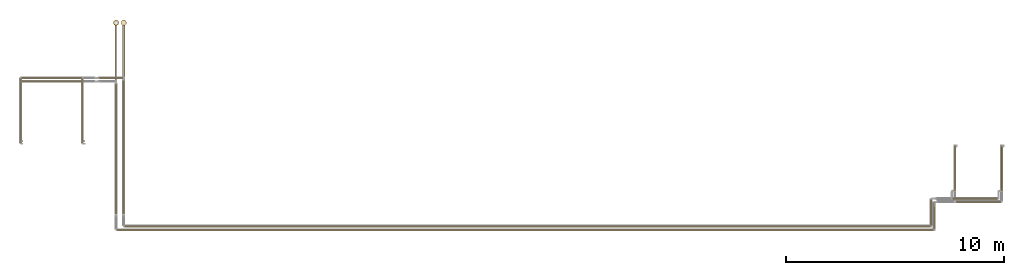
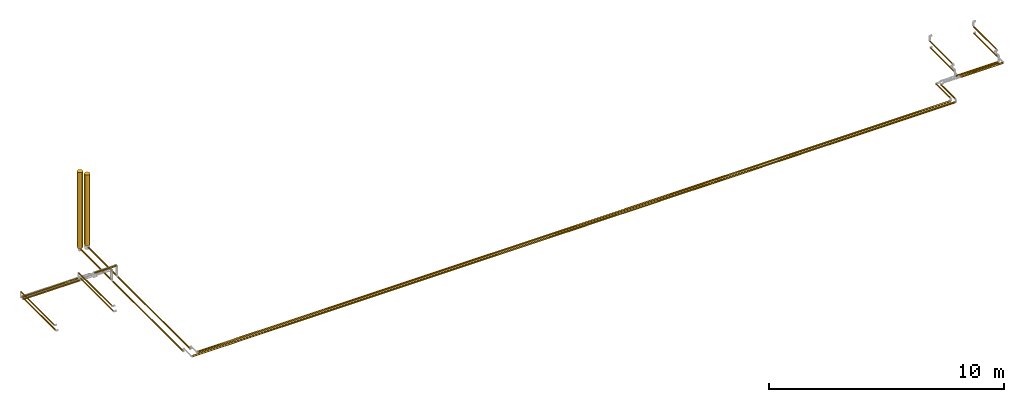
# One storey, part 1 of 39: 23 coverings.
"""IFC2X3 building model written with IfcOpenShell, lengths in millimetres."""

from ifc_helpers import new_model, entity, si_unit, converted_unit, derived_unit, direction, frame, origin, origin_2d_with_axis, place, context, subcontext, project, spatial, circle, extrude, element, save


model = new_model("IFC2X3")

# Units and contexts
model_context = context("Model", 3, precision=0.01, world=origin(), true_north=direction((6.12303176911189e-17, 1.0)))
body_context = subcontext(model_context, "Body", "Model", "MODEL_VIEW")
ifc_project = project(units=[si_unit("LENGTHUNIT", "METRE", prefix="MILLI"), si_unit("AREAUNIT", "SQUARE_METRE"), si_unit("VOLUMEUNIT", "CUBIC_METRE"), converted_unit("PLANEANGLEUNIT", "DEGREE", entity("IfcRatioMeasure", 0.0174532925199433), si_unit("PLANEANGLEUNIT", "RADIAN"), dimensions=[0, 0, 0, 0, 0, 0, 0]), si_unit("MASSUNIT", "GRAM", prefix="KILO"), derived_unit("MASSDENSITYUNIT", [(si_unit("MASSUNIT", "GRAM", prefix="KILO"), 1), (si_unit("LENGTHUNIT", "METRE"), -3)]), derived_unit("MOMENTOFINERTIAUNIT", [(si_unit("LENGTHUNIT", "METRE"), 4)]), si_unit("TIMEUNIT", "SECOND"), si_unit("FREQUENCYUNIT", "HERTZ"), si_unit("THERMODYNAMICTEMPERATUREUNIT", "DEGREE_CELSIUS"), derived_unit("THERMALTRANSMITTANCEUNIT", [(si_unit("MASSUNIT", "GRAM", prefix="KILO"), 1), (si_unit("THERMODYNAMICTEMPERATUREUNIT", "KELVIN"), -1), (si_unit("TIMEUNIT", "SECOND"), -3)]), derived_unit("VOLUMETRICFLOWRATEUNIT", [(si_unit("LENGTHUNIT", "METRE"), 3), (si_unit("TIMEUNIT", "SECOND"), -1)]), derived_unit("MASSFLOWRATEUNIT", [(si_unit("MASSUNIT", "GRAM", prefix="KILO"), 1), (si_unit("TIMEUNIT", "SECOND"), -1)]), derived_unit("ROTATIONALFREQUENCYUNIT", [(si_unit("TIMEUNIT", "SECOND"), -1)]), si_unit("ELECTRICCURRENTUNIT", "AMPERE"), si_unit("ELECTRICVOLTAGEUNIT", "VOLT"), si_unit("POWERUNIT", "WATT"), si_unit("FORCEUNIT", "NEWTON", prefix="KILO"), si_unit("ILLUMINANCEUNIT", "LUX"), si_unit("LUMINOUSFLUXUNIT", "LUMEN"), si_unit("LUMINOUSINTENSITYUNIT", "CANDELA"), derived_unit("USERDEFINED", [(si_unit("MASSUNIT", "GRAM", prefix="KILO"), -1), (si_unit("LENGTHUNIT", "METRE"), -2), (si_unit("TIMEUNIT", "SECOND"), 3), (si_unit("LUMINOUSFLUXUNIT", "LUMEN"), 1)]), derived_unit("LINEARVELOCITYUNIT", [(si_unit("LENGTHUNIT", "METRE"), 1), (si_unit("TIMEUNIT", "SECOND"), -1)]), si_unit("PRESSUREUNIT", "PASCAL"), derived_unit("USERDEFINED", [(si_unit("LENGTHUNIT", "METRE"), -2), (si_unit("MASSUNIT", "GRAM", prefix="KILO"), 1), (si_unit("TIMEUNIT", "SECOND"), -2)]), derived_unit("LINEARFORCEUNIT", [(si_unit("MASSUNIT", "GRAM", prefix="KILO"), 1), (si_unit("LENGTHUNIT", "METRE"), 1), (si_unit("TIMEUNIT", "SECOND"), -2), (si_unit("LENGTHUNIT", "METRE"), -1)]), derived_unit("PLANARFORCEUNIT", [(si_unit("MASSUNIT", "GRAM", prefix="KILO"), 1), (si_unit("LENGTHUNIT", "METRE"), 1), (si_unit("TIMEUNIT", "SECOND"), -2), (si_unit("LENGTHUNIT", "METRE"), -2)])], contexts=[model_context])

# Site, building, storey
site_placement = place(None, origin())
site = spatial("IfcSite", under=ifc_project, at=site_placement, CompositionType="ELEMENT")
building_placement = place(site_placement, origin())
building = spatial("IfcBuilding", under=site, at=building_placement, CompositionType="ELEMENT")
storey_placement = place(building_placement, frame((0.0, 0.0, 24000.0)))
storey = spatial("IfcBuildingStorey", under=building, at=storey_placement, Name="07", CompositionType="ELEMENT", Elevation=24000.0)

# Coverings
covering_1_placement = place(storey_placement, frame((30953.9, 10823.9, 2737.5)))
element("IfcCovering", 1, at=covering_1_placement, inside=storey, Name=":ADSK_", ObjectType=":ADSK_", PredefinedType="INSULATION", context=body_context, shape_type="SweptSolid", body=[
    extrude(circle(Radius=124.5, at=origin_2d_with_axis()), frame((126.1, 126.1, 0.0)), (0.0, 0.0, 1.0), 3962.49578621979),
])
covering_2_placement = place(storey_placement, frame((29502.38, 5434.02, 3266.65)))
element("IfcCovering", 2, at=covering_2_placement, inside=storey, Name=":ADSK_", ObjectType=":ADSK_", PredefinedType="INSULATION", context=body_context, shape_type="SweptSolid", body=[
    extrude(circle(Radius=31.75, at=origin_2d_with_axis()), frame((33.35, 0.0, 33.35), z_axis=(0.0, 1.0, 0.0), x_axis=(-1.0, 0.0, 0.0)), (0.0, 0.0, 1.0), 2779.0585739111),
])
covering_3_placement = place(storey_placement, frame((31039.4, 8308.17, 2619.4)))
element("IfcCovering", 3, at=covering_3_placement, inside=storey, Name=":ADSK_", ObjectType=":ADSK_", PredefinedType="INSULATION", context=body_context, shape_type="SweptSolid", body=[
    extrude(circle(Radius=39.0, at=origin_2d_with_axis()), frame((40.6, 0.0, 40.6), z_axis=(-8.05859825962109e-08, 1.0, 0.0), x_axis=(-1.0, -8.05859825962109e-08, 0.0)), (0.0, 0.0, 1.0), 2559.32784020576),
])
covering_4_placement = place(storey_placement, frame((26738.11, 8217.83, 3166.65)))
element("IfcCovering", 4, at=covering_4_placement, inside=storey, Name=":ADSK_", ObjectType=":ADSK_", PredefinedType="INSULATION", context=body_context, shape_type="SweptSolid", body=[
    extrude(circle(Radius=31.75, at=origin_2d_with_axis()), frame((0.0, 33.35, 33.35), z_axis=(1.0, 0.0, 0.0), x_axis=(0.0, -1.0, 0.0)), (0.0, 0.0, 1.0), 2759.61647043295),
])
covering_5_placement = place(storey_placement, frame((31127.93, 1393.43, 2787.76)))
element("IfcCovering", 5, at=covering_5_placement, inside=storey, Name=":ADSK_", ObjectType=":ADSK_", PredefinedType="INSULATION", context=body_context, shape_type="SweptSolid", body=[
    extrude(circle(Radius=36.15, at=origin_2d_with_axis()), frame((0.07, 37.75, 37.75), z_axis=(0.999998003749725, 0.0, 0.00199812326063139), x_axis=(0.0, -1.0, 0.0)), (0.0, 0.0, 1.0), 37494.2510963846),
])
covering_6_placement = place(storey_placement, frame((68632.33, 1479.17, 2992.21)))
element("IfcCovering", 6, at=covering_6_placement, inside=storey, Name=":ADSK_", ObjectType=":ADSK_", PredefinedType="INSULATION", context=body_context, shape_type="SweptSolid", body=[
    extrude(circle(Radius=36.15, at=origin_2d_with_axis()), frame((37.75, 0.0, 37.75), z_axis=(0.0, 1.0, 0.0), x_axis=(-1.0, 0.0, 0.0)), (0.0, 0.0, 1.0), 1198.17997233305),
])
covering_7_placement = place(storey_placement, frame((31042.25, 2169.96, 2622.25)))
element("IfcCovering", 7, at=covering_7_placement, inside=storey, Name=":ADSK_", ObjectType=":ADSK_", PredefinedType="INSULATION", context=body_context, shape_type="SweptSolid", body=[
    extrude(circle(Radius=36.15, at=origin_2d_with_axis()), frame((37.75, 0.0, 37.75), z_axis=(0.0, 1.0, 0.0), x_axis=(1.0, 0.0, 0.0)), (0.0, 0.0, 1.0), 5960.21320346263),
])
covering_8_placement = place(storey_placement, frame((26666.76, 5434.02, 3266.65)))
element("IfcCovering", 8, at=covering_8_placement, inside=storey, Name=":ADSK_", ObjectType=":ADSK_", PredefinedType="INSULATION", context=body_context, shape_type="SweptSolid", body=[
    extrude(circle(Radius=31.75, at=origin_2d_with_axis()), frame((33.35, 0.0, 33.35), z_axis=(0.0, 1.0, 0.0), x_axis=(-1.0, 0.0, 0.0)), (0.0, 0.0, 1.0), 2779.15426085327),
])
for number, where, name in (
    (9, (71731.67, 3246.35, 3046.65), ":ADSK_"),
    (10, (69581.67, 3246.35, 3046.65), ":ADSK_"),
):
    element("IfcCovering", number, at=place(storey_placement, frame(where)), inside=storey, Name=name, ObjectType=":ADSK_", PredefinedType="INSULATION", context=body_context, shape_type="SweptSolid", body=[
        extrude(circle(Radius=31.75, at=origin_2d_with_axis()), frame((33.35, 0.0, 33.35), z_axis=(0.0, 1.0, 0.0), x_axis=(1.0, 0.0, 0.0)), (0.0, 0.0, 1.0), 1983.00000000005),
    ])
covering_9_placement = place(storey_placement, frame((69663.01, 2687.61, 3042.22)))
element("IfcCovering", 11, at=covering_9_placement, inside=storey, Name=":ADSK_", ObjectType=":ADSK_", PredefinedType="INSULATION", context=body_context, shape_type="SweptSolid", body=[
    extrude(circle(Radius=36.15, at=origin_2d_with_axis()), frame((0.0, 37.75, 37.75), z_axis=(1.0, 0.0, 1.50942445411724e-05), x_axis=(0.0, -1.0, 0.0)), (0.0, 0.0, 1.0), 2054.00000021723),
])
covering_10_placement = place(storey_placement, frame((31392.25, 2169.96, 2622.25)))
element("IfcCovering", 12, at=covering_10_placement, inside=storey, Name=":ADSK_", ObjectType=":ADSK_", PredefinedType="INSULATION", context=body_context, shape_type="SweptSolid", body=[
    extrude(circle(Radius=36.15, at=origin_2d_with_axis()), frame((37.75, 0.0, 37.75), z_axis=(0.0, 1.0, 0.0), x_axis=(1.0, 0.0, 0.0)), (0.0, 0.0, 1.0), 6119.00000000001),
])
covering_11_placement = place(storey_placement, frame((31303.9, 10823.9, 2762.5)))
element("IfcCovering", 13, at=covering_11_placement, inside=storey, Name=":ADSK_", ObjectType=":ADSK_", PredefinedType="INSULATION", context=body_context, shape_type="SweptSolid", body=[
    extrude(circle(Radius=124.5, at=origin_2d_with_axis()), frame((126.1, 126.1, 0.0)), (0.0, 0.0, 1.0), 3687.50000000001),
])
covering_12_placement = place(storey_placement, frame((26666.76, 5554.02, 3466.65)))
element("IfcCovering", 14, at=covering_12_placement, inside=storey, Name=":ADSK_", ObjectType=":ADSK_", PredefinedType="INSULATION", context=body_context, shape_type="SweptSolid", body=[
    extrude(circle(Radius=31.75, at=origin_2d_with_axis()), frame((33.35, 0.0, 33.35), z_axis=(0.0, 1.0, 0.0), x_axis=(-1.0, 0.0, 0.0)), (0.0, 0.0, 1.0), 2817.94105741771),
])
covering_13_placement = place(storey_placement, frame((30314.2, 8376.61, 3166.65)))
element("IfcCovering", 15, at=covering_13_placement, inside=storey, Name=":ADSK_", ObjectType=":ADSK_", PredefinedType="INSULATION", context=body_context, shape_type="SweptSolid", body=[
    extrude(circle(Radius=31.75, at=origin_2d_with_axis()), frame((0.0, 33.35, 33.35), z_axis=(1.0, 0.0, 0.0), x_axis=(0.0, 1.0, 0.0)), (0.0, 0.0, 1.0), 1077.79898805153),
])
covering_14_placement = place(storey_placement, frame((31477.93, 1563.43, 2788.31)))
element("IfcCovering", 16, at=covering_14_placement, inside=storey, Name=":ADSK_", ObjectType=":ADSK_", PredefinedType="INSULATION", context=body_context, shape_type="SweptSolid", body=[
    extrude(circle(Radius=36.15, at=origin_2d_with_axis()), frame((0.07, 37.75, 37.75), z_axis=(0.999998000006, 0.0, 0.00199999600001203), x_axis=(0.0, -1.0, 0.0)), (0.0, 0.0, 1.0), 36994.2481264686),
])
covering_15_placement = place(storey_placement, frame((68482.33, 1649.17, 2992.16)))
element("IfcCovering", 17, at=covering_15_placement, inside=storey, Name=":ADSK_", ObjectType=":ADSK_", PredefinedType="INSULATION", context=body_context, shape_type="SweptSolid", body=[
    extrude(circle(Radius=36.15, at=origin_2d_with_axis()), frame((37.75, 0.0, 37.75), z_axis=(0.0, 0.999999996965674, 7.79015519773411e-05), x_axis=(-1.0, 0.0, 0.0)), (0.0, 0.0, 1.0), 1178.18761072129),
])
covering_16_placement = place(storey_placement, frame((31389.4, 8466.96, 2619.4)))
element("IfcCovering", 18, at=covering_16_placement, inside=storey, Name=":ADSK_", ObjectType=":ADSK_", PredefinedType="INSULATION", context=body_context, shape_type="SweptSolid", body=[
    extrude(circle(Radius=39.0, at=origin_2d_with_axis()), frame((40.6, 0.0, 40.6), z_axis=(0.0, 1.0, 0.0), x_axis=(-1.0, 0.0, 0.0)), (0.0, 0.0, 1.0), 2375.54104362635),
])
covering_17_placement = place(storey_placement, frame((29502.38, 5554.02, 3466.65)))
element("IfcCovering", 19, at=covering_17_placement, inside=storey, Name=":ADSK_", ObjectType=":ADSK_", PredefinedType="INSULATION", context=body_context, shape_type="SweptSolid", body=[
    extrude(circle(Radius=31.75, at=origin_2d_with_axis()), frame((33.35, 0.0, 33.35), z_axis=(0.0, 1.0, 0.0), x_axis=(-1.0, 0.0, 0.0)), (0.0, 0.0, 1.0), 2817.94105741771),
])
covering_18_placement = place(storey_placement, frame((26738.11, 8376.61, 3166.65)))
element("IfcCovering", 20, at=covering_18_placement, inside=storey, Name=":ADSK_", ObjectType=":ADSK_", PredefinedType="INSULATION", context=body_context, shape_type="SweptSolid", body=[
    extrude(circle(Radius=31.75, at=origin_2d_with_axis()), frame((0.0, 33.35, 33.35), z_axis=(1.0, 0.0, 0.0), x_axis=(0.0, 1.0, 0.0)), (0.0, 0.0, 1.0), 2759.61647043289),
])
for number, where, name in (
    (21, (71731.67, 3334.35, 3366.65), ":ADSK_"),
    (22, (69581.67, 3334.35, 3366.65), ":ADSK_"),
):
    element("IfcCovering", number, at=place(storey_placement, frame(where)), inside=storey, Name=name, ObjectType=":ADSK_", PredefinedType="INSULATION", context=body_context, shape_type="SweptSolid", body=[
        extrude(circle(Radius=31.75, at=origin_2d_with_axis()), frame((33.35, 0.0, 33.35), z_axis=(0.0, 1.0, 0.0), x_axis=(1.0, 0.0, 0.0)), (0.0, 0.0, 1.0), 1963.00000000006),
    ])
covering_19_placement = place(storey_placement, frame((69513.01, 2837.61, 3042.25)))
element("IfcCovering", 23, at=covering_19_placement, inside=storey, Name=":ADSK_", ObjectType=":ADSK_", PredefinedType="INSULATION", context=body_context, shape_type="SweptSolid", body=[
    extrude(circle(Radius=36.15, at=origin_2d_with_axis()), frame((0.0, 37.75, 37.75), z_axis=(1.0, 0.0, 0.0), x_axis=(0.0, -1.0, 0.0)), (0.0, 0.0, 1.0), 2054.0),
])

save(model, "model.ifc")
